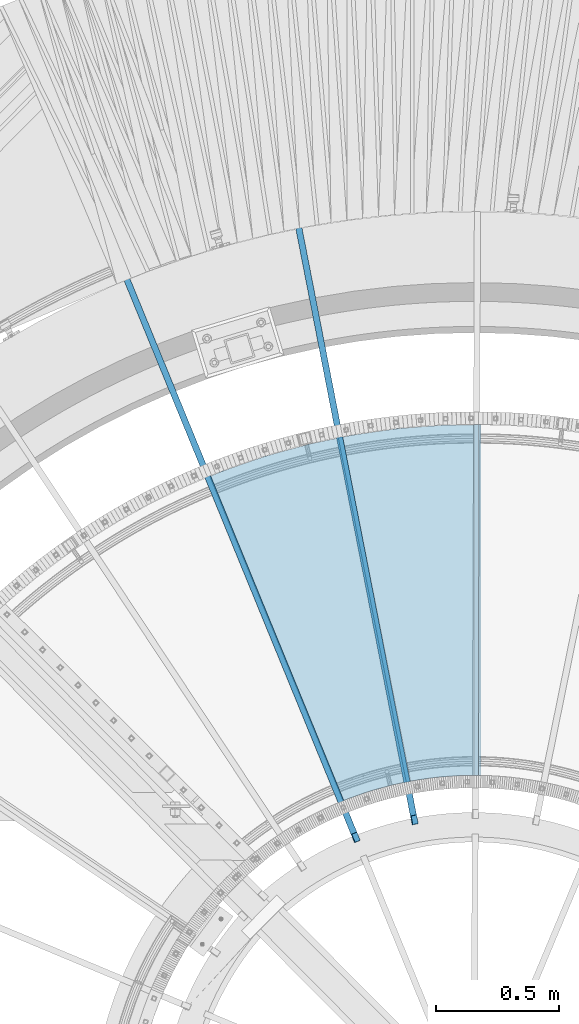
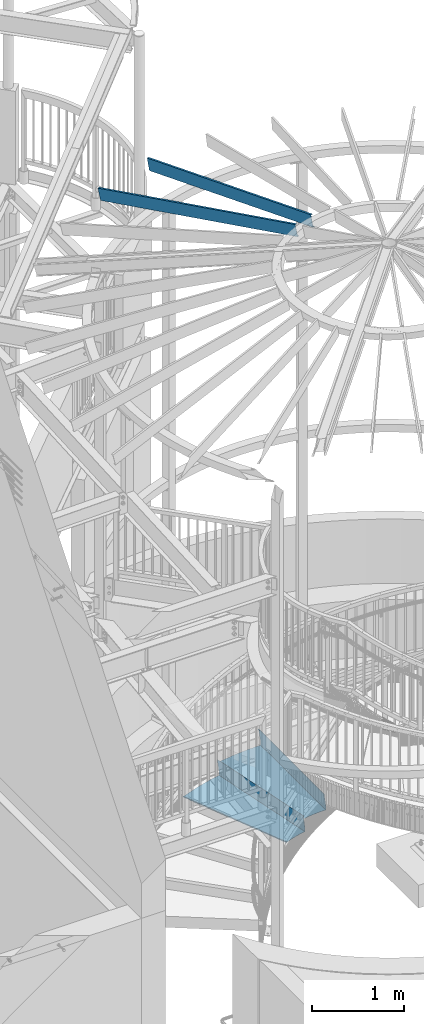
# One storey, part 354 of 975: 4 beams.
"""IFC2X3 building model written with IfcOpenShell, lengths in millimetres."""

from ifc_helpers import new_model, si_unit, frame, origin_with_axes, place, context, subcontext, project, spatial, faceted_brep, material, type_object, element, save


model = new_model("IFC2X3")

# Units and contexts
model_context = context("Model", 3, precision=1e-05, world=origin_with_axes())
body_context = subcontext(model_context, "Body", "Model", "MODEL_VIEW")
ifc_project = project(units=[si_unit("LENGTHUNIT", "METRE", prefix="MILLI"), si_unit("AREAUNIT", "SQUARE_METRE"), si_unit("VOLUMEUNIT", "CUBIC_METRE"), si_unit("MASSUNIT", "GRAM", prefix="KILO"), si_unit("TIMEUNIT", "SECOND"), si_unit("PLANEANGLEUNIT", "RADIAN"), si_unit("SOLIDANGLEUNIT", "STERADIAN"), si_unit("THERMODYNAMICTEMPERATUREUNIT", "DEGREE_CELSIUS"), si_unit("LUMINOUSINTENSITYUNIT", "LUMEN")], contexts=[model_context])

# Site, building, storey
site_placement = place(None, origin_with_axes())
site = spatial("IfcSite", under=ifc_project, at=site_placement, CompositionType="ELEMENT")
building_placement = place(site_placement, origin_with_axes())
building = spatial("IfcBuilding", under=site, at=building_placement, Name="Undefined", CompositionType="ELEMENT")
storey_placement = place(building_placement, origin_with_axes())
storey = spatial("IfcBuildingStorey", under=building, at=storey_placement, Name="Undefined", CompositionType="ELEMENT", Elevation=0.0)

# Beams
ifc_material_1 = material(Name="STEEL/A36")
beam_type_1 = type_object("IfcBeamType", PredefinedType="NOTDEFINED")
beam_1_placement = place(storey_placement, frame((34751.3283728016, 5593.71887969393, 1047.71695574218), z_axis=(-4.386945242004e-06, 0.999999999990377, -5.47593117516953e-11), x_axis=(-0.707106781183101, -3.10200000836491e-06, 0.70710678118319)))
element("IfcBeam", 1, at=beam_1_placement, inside=storey, type_object=beam_type_1, material=ifc_material_1, Name="TREAD", context=body_context, shape_type="Brep", body=[
    faceted_brep([(25.4000001621371, 1.5874997143419, 653.28751700326), (1.61144271260127e-08, 1.58750000026703, 653.458911680114), (-1.96268956642598e-08, -1.58749999973588, 653.437487347819), (15.8745748038546, -1.5875001784334, 653.330368544412), (-120.373022221533, -103.76749224318, 653.560250726816), (-154.208562872085, -137.603032237963, 653.560249286144), (-49.0005534961238, -242.811041643061, 652.140399877677), (-46.7554894721361, -240.565977619684, 652.140399877557), (-149.718432901582, -137.603030988068, 653.529952160912), (-118.287540217565, -106.172138299769, 653.529952144057), (82.2634121742994, -374.075007349978, 638.193006315465), (84.508476198167, -371.829943326711, 638.193006315345), (212.601306559884, -504.412901568812, 612.134347567509), (214.846370562875, -502.167837565145, 612.134347570151), (261.055176792581, -530.596712595621, 601.111823144849), (259.197053542079, -528.103470062568, 601.754434690294), (248.701623596196, -536.023091227627, 602.134831213494), (248.362633442506, -540.174228440612, 601.571851715846), (250.921725105154, -538.24319290819, 601.479100122608), (25.4000001865188, 1.58749971376164, -768.618736200977), (-118.287540216395, -106.172138302336, -768.542582766611), (-149.718433278054, -137.603031368186, -768.542582749815), (-92.8426928760819, -194.478774201189, -768.783692225286), (-95.087756899542, -196.723838224048, -768.783692225159), (-154.208562871598, -137.603032235413, -768.533065523057), (-120.373022220361, -103.767492245748, -768.533065418116), (15.8745748282345, -1.58750017901184, -768.605275732323), (-1.58015609486029e-08, -1.58750000031432, -768.571627720263), (1.99397618416697e-08, 1.58749999968677, -768.564897939472), (-21.2434099455131, -266.078057151808, -776.330856581004), (-23.4884739689005, -268.323121174595, -776.330856580884), (49.7927349215133, -337.114201961485, -791.08236047571), (47.5476709198538, -339.35926596382, -791.082360478347), (66.437802308692, -335.979336534963, -793.502619428495), (56.3071310127107, -343.628597994977, -793.115412720523), (53.7487404151489, -345.560335457225, -793.01762786691), (54.0919957188744, -341.413461775162, -792.424099714608), (64.5845451579717, -333.490960101732, -792.825137753654)], [[[0, 1, 2, 3, 4, 5, 6, 7, 8, 9]], [[7, 6, 10, 11]], [[11, 10, 12, 13]], [[14, 15, 16, 13, 12, 17, 18]], [[19, 20, 21, 22, 23, 24, 25, 26, 27, 28]], [[29, 30, 23, 22]], [[31, 32, 30, 29]], [[33, 34, 35, 32, 31, 36, 37]], [[34, 33, 14, 18]], [[35, 34, 18, 17]], [[10, 6, 5, 24, 23, 30, 32, 35, 17, 12]], [[25, 24, 5, 4]], [[26, 25, 4, 3]], [[27, 26, 3, 2]], [[28, 27, 2, 1]], [[19, 28, 1, 0]], [[20, 19, 0, 9]], [[20, 9, 8, 21]], [[36, 31, 29, 22, 21, 8, 7, 11, 13, 16]], [[37, 36, 16, 15]], [[33, 37, 15, 14]]]),
])
beam_2_placement = place(storey_placement, frame((34326.963578266, 5555.53354132968, 869.916955742184), z_axis=(-0.193622265294529, 0.981076153202296, 2.49789422923641e-10), x_axis=(-0.693725600969337, -0.13691161699394, 0.707106780968643)))
element("IfcBeam", 2, at=beam_2_placement, inside=storey, type_object=beam_type_1, material=ifc_material_1, Name="TREAD", context=body_context, shape_type="Brep", body=[
    faceted_brep([(25.4000001621371, 1.5874997143419, 653.28751700326), (1.61144271260127e-08, 1.58750000026703, 653.458911680114), (-1.96268956642598e-08, -1.58749999973588, 653.437487347819), (15.8745748038546, -1.5875001784334, 653.330368544412), (-120.373022221533, -103.76749224318, 653.560250726816), (-154.208562872085, -137.603032237963, 653.560249286144), (-49.0005534961238, -242.811041643061, 652.140399877677), (-46.7554894721361, -240.565977619684, 652.140399877557), (-149.718432901582, -137.603030988068, 653.529952160912), (-118.287540217565, -106.172138299769, 653.529952144057), (82.2634121742994, -374.075007349978, 638.193006315465), (84.508476198167, -371.829943326711, 638.193006315345), (212.601306559884, -504.412901568812, 612.134347567509), (214.846370562875, -502.167837565145, 612.134347570151), (261.055176792581, -530.596712595621, 601.111823144849), (259.197053542079, -528.103470062568, 601.754434690294), (248.701623596196, -536.023091227627, 602.134831213494), (248.362633442506, -540.174228440612, 601.571851715846), (250.921725105154, -538.24319290819, 601.479100122608), (25.4000001865188, 1.58749971376164, -768.618736200977), (-118.287540216395, -106.172138302336, -768.542582766611), (-149.718433278054, -137.603031368186, -768.542582749815), (-92.8426928760819, -194.478774201189, -768.783692225286), (-95.087756899542, -196.723838224048, -768.783692225159), (-154.208562871598, -137.603032235413, -768.533065523057), (-120.373022220361, -103.767492245748, -768.533065418116), (15.8745748282345, -1.58750017901184, -768.605275732323), (-1.58015609486029e-08, -1.58750000031432, -768.571627720263), (1.99397618416697e-08, 1.58749999968677, -768.564897939472), (-21.2434099455131, -266.078057151808, -776.330856581004), (-23.4884739689005, -268.323121174595, -776.330856580884), (49.7927349215133, -337.114201961485, -791.08236047571), (47.5476709198538, -339.35926596382, -791.082360478347), (66.437802308692, -335.979336534963, -793.502619428495), (56.3071310127107, -343.628597994977, -793.115412720523), (53.7487404151489, -345.560335457225, -793.01762786691), (54.0919957188744, -341.413461775162, -792.424099714608), (64.5845451579717, -333.490960101732, -792.825137753654)], [[[0, 1, 2, 3, 4, 5, 6, 7, 8, 9]], [[7, 6, 10, 11]], [[11, 10, 12, 13]], [[14, 15, 16, 13, 12, 17, 18]], [[19, 20, 21, 22, 23, 24, 25, 26, 27, 28]], [[29, 30, 23, 22]], [[31, 32, 30, 29]], [[33, 34, 35, 32, 31, 36, 37]], [[34, 33, 14, 18]], [[35, 34, 18, 17]], [[10, 6, 5, 24, 23, 30, 32, 35, 17, 12]], [[25, 24, 5, 4]], [[26, 25, 4, 3]], [[27, 26, 3, 2]], [[28, 27, 2, 1]], [[19, 28, 1, 0]], [[20, 19, 0, 9]], [[20, 9, 8, 21]], [[36, 31, 29, 22, 21, 8, 7, 11, 13, 16]], [[37, 36, 16, 15]], [[33, 37, 15, 14]]]),
])
ifc_material_2 = material(Name="STEEL/Zero_Density")
beam_type_2 = type_object("IfcBeamType", PredefinedType="NOTDEFINED")
for number, where, z_axis, x_axis, name in (
    (3, (34491.7998101186, 4645.72847900814, 8885.0313138005), (-0.0464456919896693, 0.23805333194703, 0.970140922157455), (-0.185777631923843, 0.952186998609667, -0.242541936900574), "STUD"),
    (4, (34254.1359812582, 4574.51287038351, 8885.0313138005), (-0.091995151989293, 0.224418098973874, 0.970140922167197), (-0.367970434790039, 0.897647574487811, -0.242541936861608), "STUD"),
):
    element("IfcBeam", number, at=place(storey_placement, frame(where, z_axis=z_axis, x_axis=x_axis)), inside=storey, type_object=beam_type_2, material=ifc_material_2, Name=name, context=body_context, shape_type="Brep", body=[
        faceted_brep([(-1.67347025126219e-10, 12.6999999998588, -76.2000000000985), (1.96450855582952e-10, 12.7000000001644, 76.2000000001021), (2798.98467503002, 12.7000000041553, 76.2000000028588), (2798.98467502966, 12.7000000038533, -76.1999999973427), (1.74622982740402e-10, -12.6999999998661, 76.2000000000985), (2798.98467503, -12.6999999958753, 76.2000000028534), (1.67347025126219e-10, -12.6999999998698, 73.0250000000947), (2798.98467502999, -12.6999999958789, 73.0250000028504), (1.89174897968769e-10, 9.52500000015425, 73.0250000000974), (2798.98467503001, 9.52500000414511, 73.0250000028532), (-1.60071067512035e-10, 9.52499999986321, -73.0250000000938), (2798.98467502966, 9.52500000385407, -73.0249999973398), (-1.81898940354586e-10, -12.7000000001608, -73.0250000000965), (2798.98467502964, -12.6999999961699, -73.0249999973416), (-1.92812876775861e-10, -12.7000000001717, -76.2000000001003), (2798.98467502963, -12.6999999961772, -76.1999999973455)], [[[0, 1, 2, 3]], [[1, 4, 5, 2]], [[4, 6, 7, 5]], [[6, 8, 9, 7]], [[8, 10, 11, 9]], [[10, 12, 13, 11]], [[12, 14, 15, 13]], [[14, 0, 3, 15]], [[5, 7, 9, 11, 13, 15, 3, 2]], [[14, 12, 10, 8, 6, 4, 1, 0]]]),
    ])

save(model, "model.ifc")
